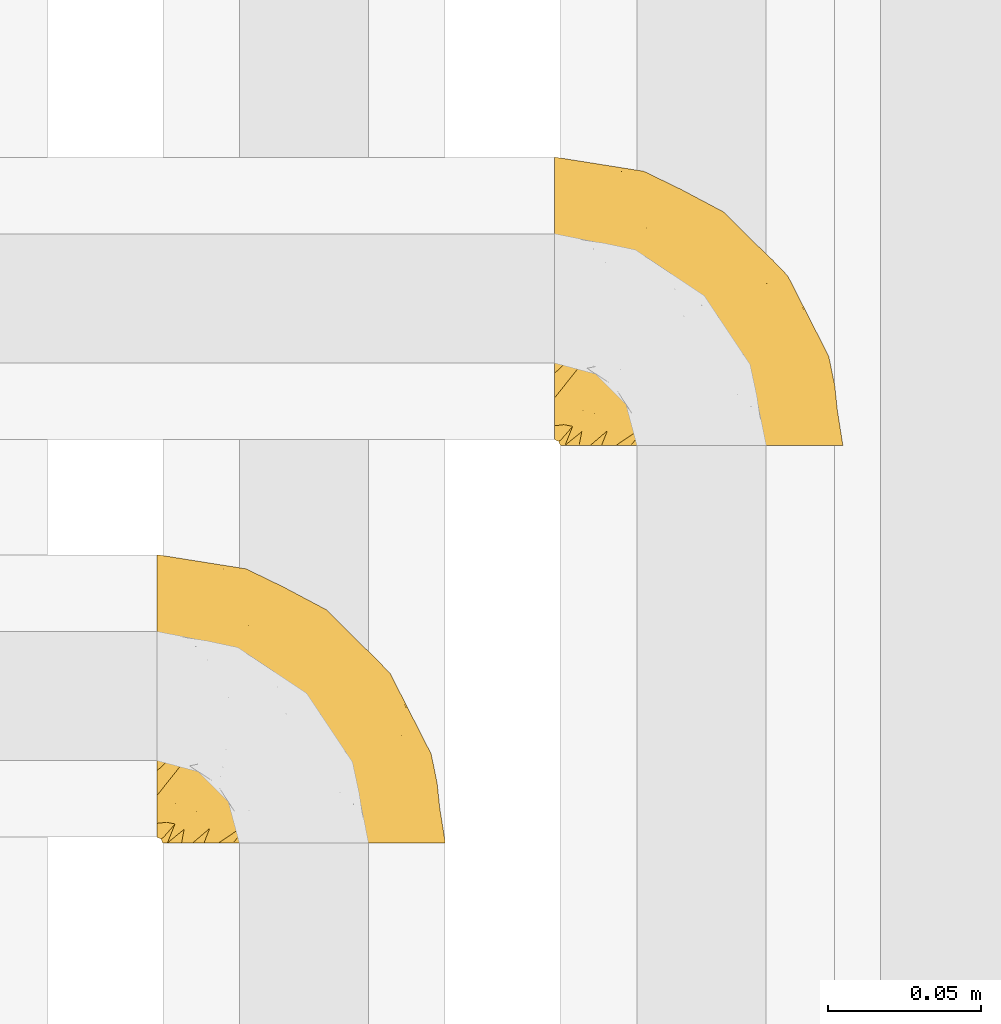
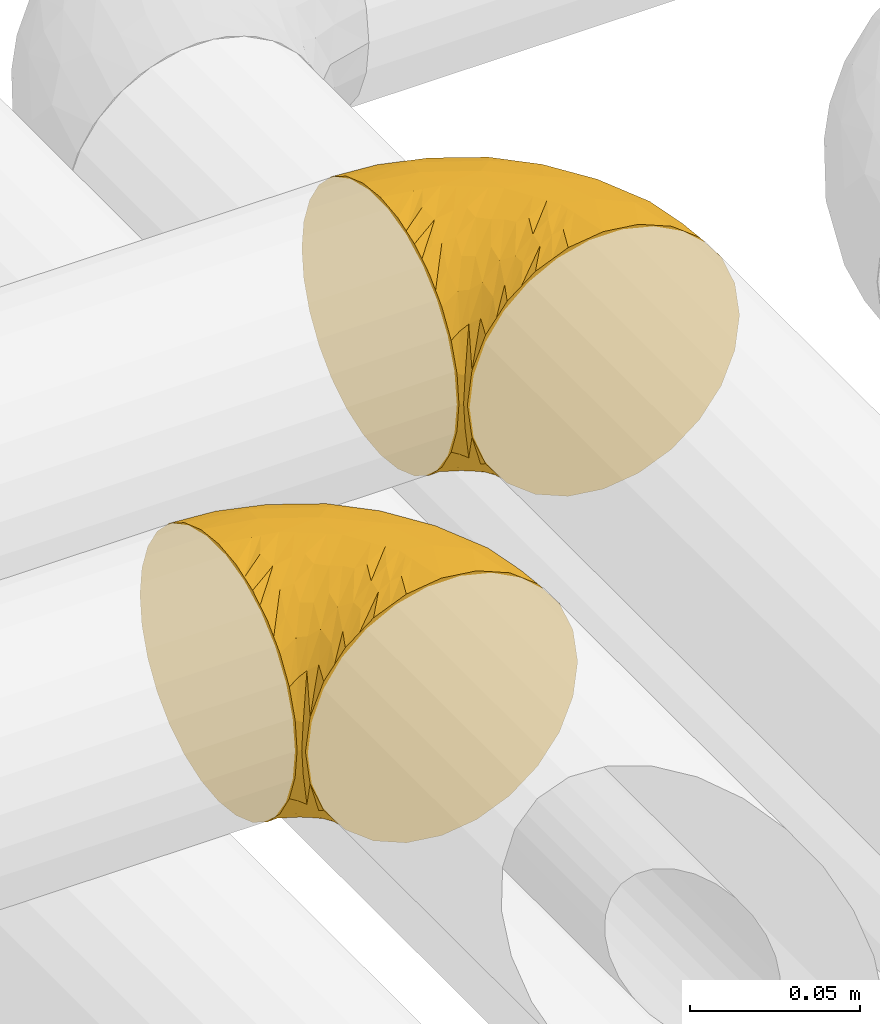
# One storey, part 253 of 827: 2 coverings.
"""IFC2X3 building model written with IfcOpenShell, lengths in millimetres."""

from ifc_helpers import new_model, entity, si_unit, converted_unit, derived_unit, direction, frame, origin, place, context, subcontext, project, spatial, faceted_brep, element, save


model = new_model("IFC2X3")

# Units and contexts
model_context = context("Model", 3, precision=0.01, world=origin(), true_north=direction((6.12303176911189e-17, 1.0)))
body_context = subcontext(model_context, "Body", "Model", "MODEL_VIEW")
ifc_project = project(units=[si_unit("LENGTHUNIT", "METRE", prefix="MILLI"), si_unit("AREAUNIT", "SQUARE_METRE"), si_unit("VOLUMEUNIT", "CUBIC_METRE"), converted_unit("PLANEANGLEUNIT", "DEGREE", entity("IfcRatioMeasure", 0.0174532925199433), si_unit("PLANEANGLEUNIT", "RADIAN"), dimensions=[0, 0, 0, 0, 0, 0, 0]), si_unit("MASSUNIT", "GRAM", prefix="KILO"), derived_unit("MASSDENSITYUNIT", [(si_unit("MASSUNIT", "GRAM", prefix="KILO"), 1), (si_unit("LENGTHUNIT", "METRE"), -3)]), derived_unit("MOMENTOFINERTIAUNIT", [(si_unit("LENGTHUNIT", "METRE"), 4)]), si_unit("TIMEUNIT", "SECOND"), si_unit("FREQUENCYUNIT", "HERTZ"), si_unit("THERMODYNAMICTEMPERATUREUNIT", "DEGREE_CELSIUS"), derived_unit("THERMALTRANSMITTANCEUNIT", [(si_unit("MASSUNIT", "GRAM", prefix="KILO"), 1), (si_unit("THERMODYNAMICTEMPERATUREUNIT", "KELVIN"), -1), (si_unit("TIMEUNIT", "SECOND"), -3)]), derived_unit("VOLUMETRICFLOWRATEUNIT", [(si_unit("LENGTHUNIT", "METRE"), 3), (si_unit("TIMEUNIT", "SECOND"), -1)]), derived_unit("MASSFLOWRATEUNIT", [(si_unit("MASSUNIT", "GRAM", prefix="KILO"), 1), (si_unit("TIMEUNIT", "SECOND"), -1)]), derived_unit("ROTATIONALFREQUENCYUNIT", [(si_unit("TIMEUNIT", "SECOND"), -1)]), si_unit("ELECTRICCURRENTUNIT", "AMPERE"), si_unit("ELECTRICVOLTAGEUNIT", "VOLT"), si_unit("POWERUNIT", "WATT"), si_unit("FORCEUNIT", "NEWTON", prefix="KILO"), si_unit("ILLUMINANCEUNIT", "LUX"), si_unit("LUMINOUSFLUXUNIT", "LUMEN"), si_unit("LUMINOUSINTENSITYUNIT", "CANDELA"), derived_unit("USERDEFINED", [(si_unit("MASSUNIT", "GRAM", prefix="KILO"), -1), (si_unit("LENGTHUNIT", "METRE"), -2), (si_unit("TIMEUNIT", "SECOND"), 3), (si_unit("LUMINOUSFLUXUNIT", "LUMEN"), 1)]), derived_unit("LINEARVELOCITYUNIT", [(si_unit("LENGTHUNIT", "METRE"), 1), (si_unit("TIMEUNIT", "SECOND"), -1)]), si_unit("PRESSUREUNIT", "PASCAL"), derived_unit("USERDEFINED", [(si_unit("LENGTHUNIT", "METRE"), -2), (si_unit("MASSUNIT", "GRAM", prefix="KILO"), 1), (si_unit("TIMEUNIT", "SECOND"), -2)]), derived_unit("LINEARFORCEUNIT", [(si_unit("MASSUNIT", "GRAM", prefix="KILO"), 1), (si_unit("LENGTHUNIT", "METRE"), 1), (si_unit("TIMEUNIT", "SECOND"), -2), (si_unit("LENGTHUNIT", "METRE"), -1)]), derived_unit("PLANARFORCEUNIT", [(si_unit("MASSUNIT", "GRAM", prefix="KILO"), 1), (si_unit("LENGTHUNIT", "METRE"), 1), (si_unit("TIMEUNIT", "SECOND"), -2), (si_unit("LENGTHUNIT", "METRE"), -2)])], contexts=[model_context])

# Site, building, storey
site_placement = place(None, origin())
site = spatial("IfcSite", under=ifc_project, at=site_placement, CompositionType="ELEMENT")
building_placement = place(site_placement, origin())
building = spatial("IfcBuilding", under=site, at=building_placement, CompositionType="ELEMENT")
storey_placement = place(building_placement, frame((0.0, 0.0, 28200.0)))
storey = spatial("IfcBuildingStorey", under=building, at=storey_placement, Name="08", CompositionType="ELEMENT", Elevation=28200.0)

# Coverings
covering_1_placement = place(storey_placement, frame((31126.93, 16011.61, 3152.2)))
element("IfcCovering", 1, at=covering_1_placement, inside=storey, Name=":ADSK_", ObjectType=":ADSK_", PredefinedType="INSULATION", context=body_context, shape_type="Brep", body=[
    faceted_brep([(1.6, 78.41, 83.91), (1.6, 85.72, 76.59), (1.6, 91.22, 67.83), (1.6, 94.64, 58.07), (1.6, 95.8, 47.8), (1.6, 94.64, 37.51), (1.6, 91.22, 27.74), (1.6, 85.71, 18.98), (1.6, 78.39, 11.67), (1.6, 69.63, 6.17), (1.6, 59.87, 2.75), (1.6, 49.6, 1.6), (1.6, 45.45, 2.06), (1.6, 42.38, 2.41), (1.6, 39.31, 2.75), (1.6, 34.43, 4.46), (1.6, 29.54, 6.17), (1.6, 25.16, 8.93), (1.6, 20.78, 11.68), (1.6, 17.13, 15.34), (1.6, 13.47, 19.0), (1.6, 7.97, 27.76), (1.6, 6.26, 32.64), (1.6, 4.55, 37.52), (1.6, 3.4, 47.8), (1.6, 4.55, 58.08), (1.6, 6.26, 62.96), (1.6, 7.97, 67.85), (1.6, 13.48, 76.61), (1.6, 17.14, 80.26), (1.6, 20.8, 83.92), (1.6, 25.18, 86.67), (1.6, 29.56, 89.42), (1.6, 34.44, 91.13), (1.6, 39.32, 92.84), (1.6, 42.39, 93.18), (1.6, 45.45, 93.53), (1.6, 49.6, 94.0), (1.6, 59.88, 92.84), (1.6, 69.65, 89.42), (3.4, 1.6, 47.8), (4.97, 1.6, 35.84), (9.58, 1.6, 24.7), (13.26, 1.6, 19.91), (16.93, 1.6, 15.13), (21.71, 1.6, 11.46), (26.5, 1.6, 7.78), (32.07, 1.6, 5.48), (37.64, 1.6, 3.17), (41.25, 1.6, 2.69), (43.34, 1.6, 2.42), (45.42, 1.6, 2.14), (49.6, 1.6, 1.6), (61.55, 1.6, 3.17), (72.7, 1.6, 7.78), (82.26, 1.6, 15.13), (89.61, 1.6, 24.7), (94.22, 1.6, 35.84), (95.8, 1.6, 47.8), (94.22, 1.6, 59.75), (89.61, 1.6, 70.9), (82.26, 1.6, 80.46), (72.7, 1.6, 87.81), (61.55, 1.6, 92.42), (49.6, 1.6, 94.0), (45.42, 1.6, 93.45), (41.25, 1.6, 92.9), (37.64, 1.6, 92.42), (32.07, 1.6, 90.11), (26.5, 1.6, 87.81), (21.71, 1.6, 84.13), (16.93, 1.6, 80.46), (13.26, 1.6, 75.68), (9.58, 1.6, 70.9), (4.97, 1.6, 59.75), (81.55, 36.81, 71.98), (90.4, 23.28, 63.6), (83.0, 45.8, 59.72), (91.18, 30.7, 47.8), (93.13, 21.2, 55.16), (94.0, 12.96, 47.8), (66.19, 66.19, 63.76), (70.92, 54.51, 72.22), (85.95, 17.98, 74.18), (49.74, 36.69, 92.52), (35.54, 35.54, 94.0), (38.14, 31.64, 94.0), (40.74, 27.75, 94.0), (43.34, 23.86, 94.0), (45.94, 19.96, 94.0), (77.59, 22.8, 82.14), (71.17, 42.67, 80.34), (65.81, 33.21, 87.52), (59.03, 59.45, 79.59), (45.85, 71.5, 78.25), (45.79, 62.66, 85.01), (41.42, 54.5, 90.25), (34.51, 47.57, 93.2), (56.04, 48.81, 87.23), (15.15, 74.98, 85.55), (56.51, 18.7, 93.0), (68.39, 15.75, 89.31), (23.33, 91.17, 61.31), (42.86, 85.28, 56.86), (39.42, 82.58, 68.34), (53.58, 75.78, 65.71), (59.17, 74.98, 56.99), (59.06, 67.27, 72.15), (22.63, 87.38, 70.34), (20.55, 82.04, 78.36), (12.96, 94.0, 47.8), (56.96, 77.8, 47.8), (67.38, 67.38, 47.8), (18.72, 56.2, 93.06), (5.33, 48.85, 94.0), (9.07, 48.11, 94.0), (11.79, 47.57, 94.0), (14.51, 47.03, 94.0), (17.24, 46.48, 94.0), (19.96, 45.94, 94.0), (21.03, 65.78, 89.88), (46.48, 17.24, 94.0), (47.03, 14.51, 94.0), (47.57, 11.79, 94.0), (48.11, 9.07, 94.0), (48.48, 7.2, 94.0), (48.85, 5.33, 94.0), (30.7, 91.18, 47.8), (23.86, 43.34, 94.0), (27.75, 40.74, 94.0), (31.64, 38.14, 94.0), (31.26, 72.73, 83.7), (77.8, 56.96, 47.8), (72.75, 62.23, 55.9), (43.83, 84.49, 47.8), (84.49, 43.83, 47.8), (14.58, 12.05, 81.75), (16.17, 18.95, 86.43), (10.82, 13.02, 79.8), (4.64, 8.34, 69.84), (7.71, 14.63, 79.5), (25.13, 11.09, 88.08), (32.66, 13.66, 91.6), (34.94, 20.08, 92.93), (36.76, 9.61, 92.43), (40.48, 9.48, 93.24), (39.25, 16.1, 93.36), (3.69, 3.42, 57.25), (13.99, 26.63, 89.41), (21.85, 33.72, 92.89), (17.93, 34.77, 92.66), (15.11, 6.75, 79.58), (21.14, 13.31, 86.51), (7.21, 19.94, 83.91), (12.7, 21.11, 86.29), (32.27, 8.67, 90.94), (25.68, 26.11, 91.94), (22.18, 29.3, 91.98), (18.79, 6.32, 82.79), (10.12, 39.92, 93.16), (9.47, 27.05, 88.76), (10.45, 6.04, 73.94), (11.29, 34.4, 91.89), (2.87, 2.87, 47.8), (31.16, 20.92, 92.22), (6.31, 27.43, 88.56), (25.62, 7.54, 87.72), (21.18, 18.45, 88.33), (28.81, 23.88, 92.18), (7.45, 7.77, 71.78), (21.17, 18.43, 7.27), (16.17, 18.93, 9.17), (25.69, 26.08, 3.66), (48.11, 9.07, 1.6), (48.85, 5.33, 1.6), (47.03, 14.51, 1.6), (47.57, 11.79, 1.6), (3.69, 3.42, 38.35), (7.44, 7.76, 23.84), (14.51, 47.03, 1.6), (11.79, 47.57, 1.6), (5.33, 48.85, 1.6), (9.07, 48.11, 1.6), (7.71, 14.62, 16.1), (9.47, 27.03, 6.84), (34.94, 20.08, 2.66), (31.16, 20.92, 3.37), (40.74, 27.75, 1.6), (38.14, 31.64, 1.6), (18.79, 6.33, 12.8), (36.76, 9.61, 3.16), (40.48, 9.48, 2.35), (4.63, 8.33, 25.77), (21.14, 13.3, 9.09), (15.11, 6.74, 16.02), (14.58, 12.04, 13.85), (43.34, 23.86, 1.6), (45.94, 19.96, 1.6), (39.25, 16.1, 2.23), (7.21, 19.93, 11.69), (12.69, 21.1, 9.31), (10.14, 39.92, 2.43), (21.81, 33.68, 2.71), (22.19, 29.28, 3.61), (14.0, 26.62, 6.18), (6.66, 27.87, 6.77), (17.92, 34.75, 2.93), (10.45, 6.04, 21.66), (31.64, 38.14, 1.6), (10.64, 12.79, 16.09), (11.31, 34.41, 3.7), (19.96, 45.94, 1.6), (23.86, 43.34, 1.6), (27.75, 40.74, 1.6), (32.66, 13.66, 3.99), (46.48, 17.24, 1.6), (32.27, 8.67, 4.65), (25.13, 11.09, 7.51), (35.54, 35.54, 1.6), (28.77, 23.83, 3.43), (23.36, 6.03, 9.46), (17.24, 46.48, 1.6), (47.58, 34.52, 2.4), (93.13, 21.2, 40.43), (77.44, 23.82, 13.57), (66.78, 41.32, 11.3), (71.68, 47.62, 18.65), (74.96, 52.66, 27.26), (81.55, 36.81, 23.61), (36.7, 49.75, 3.07), (56.9, 19.07, 2.69), (83.0, 45.8, 35.87), (90.4, 23.28, 31.99), (67.83, 21.35, 6.71), (85.95, 17.98, 21.41), (39.41, 82.57, 27.24), (23.33, 91.17, 34.26), (42.87, 85.27, 38.73), (53.92, 73.89, 26.97), (66.19, 66.19, 31.83), (64.12, 62.43, 23.4), (33.13, 63.53, 6.91), (23.1, 58.45, 3.4), (16.98, 67.16, 5.84), (55.72, 76.72, 35.73), (72.75, 62.22, 39.69), (23.77, 81.54, 17.6), (18.41, 74.8, 10.38), (43.7, 75.83, 20.6), (54.53, 41.45, 5.36), (17.73, 88.2, 24.84), (38.98, 71.6, 13.87), (50.28, 56.23, 9.06), (59.02, 59.44, 15.99)], [[[0, 1, 2, 3, 4, 5, 6, 7, 8, 9, 10, 11, 12, 13, 14, 15, 16, 17, 18, 19, 20, 21, 22, 23, 24, 25, 26, 27, 28, 29, 30, 31, 32, 33, 34, 35, 36, 37, 38, 39]], [[40, 41, 42, 43, 44, 45, 46, 47, 48, 49, 50, 51, 52, 53, 54, 55, 56, 57, 58, 59, 60, 61, 62, 63, 64, 65, 66, 67, 68, 69, 70, 71, 72, 73, 74]], [[75, 76, 77]], [[78, 79, 80]], [[77, 81, 82]], [[76, 75, 83]], [[84, 85, 86, 87, 88, 89]], [[90, 91, 92]], [[76, 60, 59]], [[93, 94, 95]], [[90, 62, 61]], [[83, 61, 60]], [[96, 97, 84]], [[98, 93, 95]], [[0, 39, 99]], [[100, 84, 89]], [[62, 101, 63]], [[2, 102, 3]], [[92, 84, 100]], [[103, 102, 104]], [[103, 105, 106]], [[93, 107, 94]], [[1, 108, 2]], [[92, 101, 90]], [[108, 1, 109]], [[102, 110, 3]], [[93, 82, 107]], [[102, 108, 104]], [[111, 106, 112]], [[109, 0, 99]], [[113, 37, 114, 115, 116, 117, 118, 119]], [[120, 38, 113]], [[100, 89, 121, 122, 123, 124, 125, 126, 64]], [[127, 102, 103]], [[97, 119, 128, 129, 130, 85]], [[99, 120, 131]], [[132, 133, 77]], [[59, 80, 79]], [[1, 0, 109]], [[98, 84, 92]], [[94, 109, 131]], [[120, 39, 38]], [[93, 91, 82]], [[104, 94, 105]], [[97, 113, 119]], [[95, 120, 96]], [[83, 90, 61]], [[91, 93, 98]], [[64, 63, 100]], [[100, 63, 101]], [[77, 76, 79]], [[133, 106, 81]], [[84, 97, 85]], [[113, 96, 120]], [[113, 97, 96]], [[37, 113, 38]], [[110, 102, 127]], [[110, 4, 3]], [[103, 111, 134, 127]], [[90, 75, 91]], [[82, 81, 107]], [[91, 75, 82]], [[77, 82, 75]], [[76, 83, 60]], [[90, 83, 75]], [[105, 107, 81]], [[94, 131, 95]], [[105, 94, 107]], [[109, 94, 104]], [[120, 95, 131]], [[98, 95, 96]], [[84, 98, 96]], [[98, 92, 91]], [[106, 105, 81]], [[103, 104, 105]], [[133, 132, 112]], [[103, 106, 111]], [[77, 78, 135, 132]], [[106, 133, 112]], [[77, 133, 81]], [[120, 99, 39]], [[109, 99, 131]], [[59, 58, 80]], [[59, 79, 76]], [[90, 101, 62]], [[100, 101, 92]], [[2, 108, 102]], [[109, 104, 108]], [[78, 77, 79]], [[136, 137, 138]], [[27, 139, 140]], [[141, 142, 143]], [[144, 145, 121]], [[146, 89, 88]], [[147, 139, 25]], [[148, 149, 150]], [[136, 151, 152]], [[147, 40, 74]], [[24, 147, 25]], [[153, 140, 154]], [[33, 116, 34]], [[73, 72, 151]], [[114, 37, 36, 35, 34, 116, 115]], [[146, 155, 144]], [[156, 85, 130]], [[157, 149, 148]], [[151, 158, 152]], [[117, 33, 159]], [[29, 153, 160]], [[161, 74, 73]], [[162, 128, 119]], [[66, 65, 64, 126, 125, 124, 123, 122, 67]], [[163, 147, 24]], [[27, 140, 28]], [[149, 129, 150]], [[139, 27, 26, 25]], [[68, 144, 69]], [[129, 128, 150]], [[164, 87, 86]], [[130, 129, 149]], [[122, 145, 67]], [[153, 154, 148]], [[162, 119, 159]], [[165, 30, 160]], [[150, 160, 148]], [[128, 162, 150]], [[30, 165, 31]], [[145, 144, 68]], [[89, 146, 144]], [[87, 164, 143]], [[166, 155, 142]], [[88, 87, 143]], [[162, 160, 150]], [[160, 30, 29]], [[160, 153, 148]], [[28, 140, 153]], [[29, 28, 153]], [[140, 137, 154]], [[157, 148, 154]], [[156, 130, 157]], [[154, 137, 157]], [[157, 137, 156]], [[167, 137, 136]], [[168, 85, 156]], [[152, 168, 167]], [[167, 168, 156]], [[164, 152, 141]], [[71, 158, 72]], [[152, 167, 136]], [[88, 142, 146]], [[144, 155, 69]], [[146, 142, 155]], [[70, 166, 71]], [[142, 141, 166]], [[70, 69, 155]], [[141, 158, 71]], [[161, 73, 151]], [[138, 137, 140]], [[161, 136, 169]], [[136, 161, 151]], [[74, 161, 169]], [[152, 158, 141]], [[151, 72, 158]], [[168, 152, 164]], [[137, 167, 156]], [[164, 86, 168]], [[85, 168, 86]], [[116, 33, 117]], [[130, 149, 157]], [[67, 145, 68]], [[121, 89, 144]], [[145, 122, 121]], [[40, 147, 163]], [[169, 147, 74]], [[159, 33, 32]], [[162, 159, 32]], [[159, 119, 118, 117]], [[139, 147, 169]], [[139, 169, 138]], [[162, 32, 31]], [[141, 143, 164]], [[88, 143, 142]], [[71, 166, 141]], [[155, 166, 70]], [[139, 138, 140]], [[169, 136, 138]], [[160, 162, 165]], [[162, 31, 165]], [[170, 171, 172]], [[173, 174, 52, 51, 50, 49, 48, 175, 176]], [[177, 178, 41]], [[179, 15, 180]], [[12, 11, 181, 182, 180, 14, 13]], [[183, 21, 20]], [[19, 18, 184]], [[185, 186, 187]], [[186, 188, 187]], [[43, 189, 44]], [[190, 191, 47]], [[23, 22, 21, 192]], [[193, 194, 195]], [[40, 163, 177]], [[196, 197, 198]], [[24, 23, 177]], [[199, 200, 183]], [[201, 15, 179]], [[47, 46, 190]], [[202, 203, 204]], [[203, 172, 171]], [[205, 206, 184]], [[207, 41, 178]], [[16, 15, 201]], [[14, 180, 15]], [[204, 203, 200]], [[208, 203, 202]], [[163, 24, 177]], [[48, 47, 191]], [[198, 197, 190]], [[199, 184, 204]], [[171, 195, 209]], [[210, 211, 212]], [[206, 212, 213]], [[205, 17, 210]], [[184, 206, 204]], [[210, 212, 206]], [[185, 196, 214]], [[190, 215, 191]], [[216, 45, 214]], [[186, 217, 193]], [[190, 216, 198]], [[199, 20, 19]], [[196, 185, 187]], [[199, 183, 20]], [[184, 199, 19]], [[199, 204, 200]], [[206, 202, 204]], [[171, 183, 200]], [[203, 208, 172]], [[172, 208, 218]], [[171, 200, 203]], [[218, 188, 219]], [[195, 170, 193]], [[217, 186, 185]], [[193, 219, 186]], [[193, 170, 219]], [[207, 194, 42]], [[217, 220, 189]], [[216, 190, 46]], [[214, 196, 198]], [[44, 220, 45]], [[214, 198, 216]], [[216, 46, 45]], [[214, 45, 220]], [[42, 194, 43]], [[189, 193, 217]], [[207, 195, 194]], [[209, 195, 178]], [[41, 207, 42]], [[195, 207, 178]], [[43, 194, 189]], [[193, 189, 194]], [[171, 170, 195]], [[170, 172, 219]], [[218, 219, 172]], [[188, 186, 219]], [[206, 213, 202]], [[208, 202, 213]], [[201, 210, 16]], [[215, 190, 197]], [[215, 175, 191]], [[175, 48, 191]], [[201, 179, 221, 211]], [[210, 201, 211]], [[23, 192, 177]], [[40, 177, 41]], [[178, 177, 192]], [[21, 183, 192]], [[209, 192, 183]], [[205, 18, 17]], [[17, 16, 210]], [[217, 185, 214]], [[189, 220, 44]], [[214, 220, 217]], [[192, 209, 178]], [[171, 209, 183]], [[206, 205, 210]], [[18, 205, 184]], [[222, 197, 196, 187, 188, 218]], [[57, 223, 80]], [[224, 225, 226]], [[226, 227, 228]], [[229, 218, 208, 213, 212, 211]], [[230, 52, 174, 173, 176, 175, 215, 197]], [[231, 232, 228]], [[231, 78, 223]], [[223, 57, 232]], [[224, 233, 225]], [[233, 54, 53]], [[234, 232, 56]], [[56, 55, 234]], [[234, 224, 228]], [[235, 236, 237]], [[224, 55, 54]], [[238, 239, 240]], [[52, 230, 53]], [[241, 242, 243]], [[239, 244, 245]], [[11, 10, 242]], [[236, 6, 5]], [[7, 246, 8]], [[8, 247, 9]], [[238, 248, 235]], [[222, 229, 249]], [[242, 211, 221, 179, 180, 182, 181, 11]], [[233, 53, 230]], [[111, 112, 244]], [[250, 6, 236]], [[247, 251, 241]], [[6, 250, 7]], [[127, 236, 110]], [[249, 229, 252]], [[247, 8, 246]], [[235, 246, 250]], [[236, 5, 110]], [[235, 244, 238]], [[237, 236, 127]], [[243, 9, 247]], [[252, 229, 241]], [[56, 232, 57]], [[222, 230, 197]], [[225, 249, 252]], [[249, 233, 230]], [[54, 233, 224]], [[231, 228, 227]], [[245, 132, 231]], [[249, 225, 233]], [[226, 225, 253]], [[235, 250, 236]], [[246, 7, 250]], [[251, 247, 246]], [[243, 247, 241]], [[248, 246, 235]], [[252, 251, 253]], [[229, 222, 218]], [[230, 222, 249]], [[5, 4, 110]], [[237, 127, 134, 111]], [[238, 244, 239]], [[224, 234, 55]], [[232, 234, 228]], [[242, 241, 229]], [[10, 9, 243]], [[211, 242, 229]], [[10, 243, 242]], [[80, 223, 78]], [[80, 58, 57]], [[231, 223, 232]], [[227, 240, 239]], [[224, 226, 228]], [[240, 226, 253]], [[227, 239, 245]], [[226, 240, 227]], [[251, 248, 253]], [[240, 253, 248]], [[244, 235, 237]], [[237, 111, 244]], [[132, 245, 112]], [[112, 245, 244]], [[135, 78, 231, 132]], [[227, 245, 231]], [[248, 238, 240]], [[246, 248, 251]], [[251, 252, 241]], [[225, 252, 253]]]),
])
covering_2_placement = place(storey_placement, frame((31256.93, 16141.61, 3152.2)))
element("IfcCovering", 2, at=covering_2_placement, inside=storey, Name=":ADSK_", ObjectType=":ADSK_", PredefinedType="INSULATION", context=body_context, shape_type="Brep", body=[
    faceted_brep([(1.6, 78.41, 83.91), (1.6, 85.72, 76.59), (1.6, 91.22, 67.83), (1.6, 94.64, 58.07), (1.6, 95.8, 47.8), (1.6, 94.64, 37.51), (1.6, 91.22, 27.74), (1.6, 85.71, 18.98), (1.6, 78.39, 11.67), (1.6, 69.63, 6.17), (1.6, 59.87, 2.75), (1.6, 49.6, 1.6), (1.6, 45.45, 2.06), (1.6, 42.38, 2.41), (1.6, 39.31, 2.75), (1.6, 34.43, 4.46), (1.6, 29.54, 6.17), (1.6, 25.16, 8.93), (1.6, 20.78, 11.68), (1.6, 17.13, 15.34), (1.6, 13.47, 19.0), (1.6, 7.97, 27.76), (1.6, 6.26, 32.64), (1.6, 4.55, 37.52), (1.6, 3.4, 47.8), (1.6, 4.55, 58.08), (1.6, 6.26, 62.96), (1.6, 7.97, 67.85), (1.6, 13.48, 76.61), (1.6, 17.14, 80.26), (1.6, 20.8, 83.92), (1.6, 25.18, 86.67), (1.6, 29.56, 89.42), (1.6, 34.44, 91.13), (1.6, 39.32, 92.84), (1.6, 42.39, 93.18), (1.6, 45.45, 93.53), (1.6, 49.6, 94.0), (1.6, 59.88, 92.84), (1.6, 69.65, 89.42), (3.4, 1.6, 47.8), (4.97, 1.6, 35.84), (9.58, 1.6, 24.7), (13.26, 1.6, 19.91), (16.93, 1.6, 15.13), (21.71, 1.6, 11.46), (26.5, 1.6, 7.78), (32.07, 1.6, 5.48), (37.64, 1.6, 3.17), (41.25, 1.6, 2.69), (43.34, 1.6, 2.42), (45.42, 1.6, 2.14), (49.6, 1.6, 1.6), (61.55, 1.6, 3.17), (72.7, 1.6, 7.78), (82.26, 1.6, 15.13), (89.61, 1.6, 24.7), (94.22, 1.6, 35.84), (95.8, 1.6, 47.8), (94.22, 1.6, 59.75), (89.61, 1.6, 70.9), (82.26, 1.6, 80.46), (72.7, 1.6, 87.81), (61.55, 1.6, 92.42), (49.6, 1.6, 94.0), (45.42, 1.6, 93.45), (41.25, 1.6, 92.9), (37.64, 1.6, 92.42), (32.07, 1.6, 90.11), (26.5, 1.6, 87.81), (21.71, 1.6, 84.13), (16.93, 1.6, 80.46), (13.26, 1.6, 75.68), (9.58, 1.6, 70.9), (4.97, 1.6, 59.75), (81.55, 36.81, 71.98), (90.4, 23.28, 63.6), (83.0, 45.8, 59.72), (91.18, 30.7, 47.8), (93.13, 21.2, 55.16), (94.0, 12.96, 47.8), (66.19, 66.19, 63.76), (70.92, 54.51, 72.22), (85.95, 17.98, 74.18), (49.74, 36.69, 92.52), (35.54, 35.54, 94.0), (38.14, 31.64, 94.0), (40.74, 27.75, 94.0), (43.34, 23.86, 94.0), (45.94, 19.96, 94.0), (77.59, 22.8, 82.14), (71.17, 42.67, 80.34), (65.81, 33.21, 87.52), (59.03, 59.45, 79.59), (45.85, 71.5, 78.25), (45.79, 62.66, 85.01), (41.42, 54.5, 90.25), (34.51, 47.57, 93.2), (56.04, 48.81, 87.23), (15.15, 74.98, 85.55), (56.51, 18.7, 93.0), (68.39, 15.75, 89.31), (23.33, 91.17, 61.31), (42.86, 85.28, 56.86), (39.42, 82.58, 68.34), (53.58, 75.78, 65.71), (59.17, 74.98, 56.99), (59.06, 67.27, 72.15), (22.63, 87.38, 70.34), (20.55, 82.04, 78.36), (12.96, 94.0, 47.8), (56.96, 77.8, 47.8), (67.38, 67.38, 47.8), (18.72, 56.2, 93.06), (5.33, 48.85, 94.0), (9.07, 48.11, 94.0), (11.79, 47.57, 94.0), (14.51, 47.03, 94.0), (17.24, 46.48, 94.0), (19.96, 45.94, 94.0), (21.03, 65.78, 89.88), (46.48, 17.24, 94.0), (47.03, 14.51, 94.0), (47.57, 11.79, 94.0), (48.11, 9.07, 94.0), (48.48, 7.2, 94.0), (48.85, 5.33, 94.0), (30.7, 91.18, 47.8), (23.86, 43.34, 94.0), (27.75, 40.74, 94.0), (31.64, 38.14, 94.0), (31.26, 72.73, 83.7), (77.8, 56.96, 47.8), (72.75, 62.23, 55.9), (43.83, 84.49, 47.8), (84.49, 43.83, 47.8), (14.58, 12.05, 81.75), (16.17, 18.95, 86.43), (10.82, 13.02, 79.8), (4.64, 8.34, 69.84), (7.71, 14.63, 79.5), (25.13, 11.09, 88.08), (32.66, 13.66, 91.6), (34.94, 20.08, 92.93), (36.76, 9.61, 92.43), (40.48, 9.48, 93.24), (39.25, 16.1, 93.36), (3.69, 3.42, 57.25), (13.99, 26.63, 89.41), (21.85, 33.72, 92.89), (17.93, 34.77, 92.66), (15.11, 6.75, 79.58), (21.14, 13.31, 86.51), (7.21, 19.94, 83.91), (9.47, 27.05, 88.76), (10.45, 6.04, 73.94), (32.27, 8.67, 90.94), (25.68, 26.11, 91.94), (22.18, 29.3, 91.98), (18.79, 6.32, 82.79), (10.12, 39.92, 93.16), (11.29, 34.4, 91.89), (2.87, 2.87, 47.8), (31.16, 20.92, 92.22), (12.7, 21.11, 86.29), (6.31, 27.43, 88.56), (25.62, 7.54, 87.72), (21.18, 18.45, 88.33), (28.81, 23.88, 92.18), (7.45, 7.77, 71.78), (21.14, 13.3, 9.09), (25.13, 11.09, 7.51), (18.79, 6.33, 12.8), (48.11, 9.07, 1.6), (48.85, 5.33, 1.6), (47.03, 14.51, 1.6), (47.57, 11.79, 1.6), (3.69, 3.42, 38.35), (7.44, 7.76, 23.84), (14.51, 47.03, 1.6), (11.79, 47.57, 1.6), (5.33, 48.85, 1.6), (9.07, 48.11, 1.6), (7.71, 14.62, 16.1), (9.47, 27.03, 6.84), (34.94, 20.08, 2.66), (31.16, 20.92, 3.37), (40.74, 27.75, 1.6), (38.14, 31.64, 1.6), (36.76, 9.61, 3.16), (40.48, 9.48, 2.35), (4.63, 8.33, 25.77), (15.11, 6.74, 16.02), (14.58, 12.04, 13.85), (43.34, 23.86, 1.6), (45.94, 19.96, 1.6), (39.25, 16.1, 2.23), (7.21, 19.93, 11.69), (12.69, 21.1, 9.31), (10.14, 39.92, 2.43), (21.81, 33.68, 2.71), (22.19, 29.28, 3.61), (14.0, 26.62, 6.18), (25.69, 26.08, 3.66), (16.17, 18.93, 9.17), (6.66, 27.87, 6.77), (17.92, 34.75, 2.93), (10.45, 6.04, 21.66), (31.64, 38.14, 1.6), (10.64, 12.79, 16.09), (11.31, 34.41, 3.7), (19.96, 45.94, 1.6), (23.86, 43.34, 1.6), (27.75, 40.74, 1.6), (32.66, 13.66, 3.99), (46.48, 17.24, 1.6), (32.27, 8.67, 4.65), (35.54, 35.54, 1.6), (28.77, 23.83, 3.43), (21.17, 18.43, 7.27), (23.36, 6.03, 9.46), (17.24, 46.48, 1.6), (47.58, 34.52, 2.4), (93.13, 21.2, 40.43), (77.44, 23.82, 13.57), (66.78, 41.32, 11.3), (71.68, 47.62, 18.65), (74.96, 52.66, 27.26), (81.55, 36.81, 23.61), (36.7, 49.75, 3.07), (56.9, 19.07, 2.69), (83.0, 45.8, 35.87), (90.4, 23.28, 31.99), (67.83, 21.35, 6.71), (85.95, 17.98, 21.41), (39.41, 82.57, 27.24), (23.33, 91.17, 34.26), (42.87, 85.27, 38.73), (53.92, 73.89, 26.97), (66.19, 66.19, 31.83), (64.12, 62.43, 23.4), (33.13, 63.53, 6.91), (23.1, 58.45, 3.4), (16.98, 67.16, 5.84), (72.75, 62.22, 39.69), (23.77, 81.54, 17.6), (18.41, 74.8, 10.38), (43.7, 75.83, 20.6), (54.53, 41.45, 5.36), (55.72, 76.72, 35.73), (17.73, 88.2, 24.84), (38.98, 71.6, 13.87), (50.28, 56.23, 9.06), (59.02, 59.44, 15.99)], [[[0, 1, 2, 3, 4, 5, 6, 7, 8, 9, 10, 11, 12, 13, 14, 15, 16, 17, 18, 19, 20, 21, 22, 23, 24, 25, 26, 27, 28, 29, 30, 31, 32, 33, 34, 35, 36, 37, 38, 39]], [[40, 41, 42, 43, 44, 45, 46, 47, 48, 49, 50, 51, 52, 53, 54, 55, 56, 57, 58, 59, 60, 61, 62, 63, 64, 65, 66, 67, 68, 69, 70, 71, 72, 73, 74]], [[75, 76, 77]], [[78, 79, 80]], [[77, 81, 82]], [[76, 75, 83]], [[84, 85, 86, 87, 88, 89]], [[90, 91, 92]], [[76, 60, 59]], [[93, 94, 95]], [[90, 62, 61]], [[83, 61, 60]], [[96, 97, 84]], [[98, 93, 95]], [[0, 39, 99]], [[100, 84, 89]], [[62, 101, 63]], [[2, 102, 3]], [[92, 84, 100]], [[103, 102, 104]], [[103, 105, 106]], [[93, 107, 94]], [[1, 108, 2]], [[92, 101, 90]], [[108, 1, 109]], [[102, 110, 3]], [[93, 82, 107]], [[102, 108, 104]], [[111, 106, 112]], [[109, 0, 99]], [[113, 37, 114, 115, 116, 117, 118, 119]], [[120, 38, 113]], [[100, 89, 121, 122, 123, 124, 125, 126, 64]], [[127, 102, 103]], [[97, 119, 128, 129, 130, 85]], [[99, 120, 131]], [[132, 133, 77]], [[59, 80, 79]], [[1, 0, 109]], [[98, 84, 92]], [[94, 109, 131]], [[120, 39, 38]], [[93, 91, 82]], [[104, 94, 105]], [[97, 113, 119]], [[95, 120, 96]], [[83, 90, 61]], [[91, 93, 98]], [[64, 63, 100]], [[100, 63, 101]], [[77, 76, 79]], [[133, 106, 81]], [[84, 97, 85]], [[113, 96, 120]], [[113, 97, 96]], [[37, 113, 38]], [[110, 102, 127]], [[110, 4, 3]], [[103, 111, 134, 127]], [[90, 75, 91]], [[82, 81, 107]], [[91, 75, 82]], [[77, 82, 75]], [[76, 83, 60]], [[90, 83, 75]], [[105, 107, 81]], [[94, 131, 95]], [[105, 94, 107]], [[109, 94, 104]], [[120, 95, 131]], [[98, 95, 96]], [[84, 98, 96]], [[98, 92, 91]], [[106, 105, 81]], [[103, 104, 105]], [[133, 132, 112]], [[103, 106, 111]], [[77, 78, 135, 132]], [[106, 133, 112]], [[77, 133, 81]], [[120, 99, 39]], [[109, 99, 131]], [[59, 58, 80]], [[59, 79, 76]], [[90, 101, 62]], [[100, 101, 92]], [[2, 108, 102]], [[109, 104, 108]], [[78, 77, 79]], [[136, 137, 138]], [[27, 139, 140]], [[141, 142, 143]], [[144, 145, 121]], [[146, 89, 88]], [[147, 139, 25]], [[148, 149, 150]], [[136, 151, 152]], [[147, 40, 74]], [[24, 147, 25]], [[153, 148, 154]], [[33, 116, 34]], [[73, 151, 155]], [[114, 37, 36, 35, 34, 116, 115]], [[146, 156, 144]], [[157, 85, 130]], [[158, 149, 148]], [[151, 159, 152]], [[117, 33, 160]], [[29, 153, 154]], [[155, 74, 73]], [[161, 128, 119]], [[65, 64, 126, 125, 124, 123, 122, 67, 66]], [[162, 147, 24]], [[27, 140, 28]], [[149, 129, 150]], [[139, 27, 26, 25]], [[68, 144, 69]], [[129, 128, 150]], [[163, 87, 86]], [[130, 129, 149]], [[122, 145, 67]], [[153, 164, 148]], [[161, 119, 160]], [[165, 30, 154]], [[150, 154, 148]], [[128, 161, 150]], [[30, 165, 31]], [[145, 144, 68]], [[89, 146, 144]], [[87, 163, 143]], [[166, 156, 142]], [[88, 87, 143]], [[161, 154, 150]], [[154, 30, 29]], [[29, 28, 153]], [[28, 140, 153]], [[164, 153, 140]], [[140, 137, 164]], [[158, 148, 164]], [[157, 130, 158]], [[164, 137, 158]], [[158, 137, 157]], [[167, 137, 136]], [[168, 85, 157]], [[152, 168, 167]], [[167, 168, 157]], [[163, 152, 141]], [[151, 73, 72]], [[159, 72, 71]], [[88, 142, 146]], [[144, 156, 69]], [[146, 142, 156]], [[70, 166, 71]], [[142, 141, 166]], [[70, 69, 156]], [[141, 159, 71]], [[167, 136, 152]], [[138, 137, 140]], [[155, 136, 169]], [[136, 155, 151]], [[74, 155, 169]], [[152, 159, 141]], [[151, 72, 159]], [[168, 152, 163]], [[137, 167, 157]], [[163, 86, 168]], [[85, 168, 86]], [[116, 33, 117]], [[130, 149, 158]], [[67, 145, 68]], [[121, 89, 144]], [[145, 122, 121]], [[40, 147, 162]], [[169, 147, 74]], [[160, 33, 32]], [[161, 160, 32]], [[160, 119, 118, 117]], [[139, 147, 169]], [[139, 169, 138]], [[161, 32, 31]], [[141, 143, 163]], [[88, 143, 142]], [[71, 166, 141]], [[156, 166, 70]], [[139, 138, 140]], [[169, 136, 138]], [[154, 161, 165]], [[161, 31, 165]], [[170, 171, 172]], [[173, 174, 52, 51, 50, 49, 48, 175, 176]], [[177, 178, 41]], [[179, 15, 180]], [[12, 11, 181, 182, 180, 14, 13]], [[183, 21, 20]], [[19, 18, 184]], [[185, 186, 187]], [[186, 188, 187]], [[43, 172, 44]], [[189, 190, 47]], [[23, 22, 21, 191]], [[170, 192, 193]], [[40, 162, 177]], [[194, 195, 196]], [[24, 23, 177]], [[197, 198, 183]], [[199, 15, 179]], [[47, 46, 189]], [[200, 201, 202]], [[201, 203, 204]], [[205, 206, 184]], [[207, 41, 178]], [[16, 15, 199]], [[14, 180, 15]], [[202, 201, 198]], [[208, 201, 200]], [[162, 24, 177]], [[48, 47, 190]], [[196, 195, 189]], [[197, 184, 202]], [[204, 193, 209]], [[210, 211, 212]], [[206, 212, 213]], [[205, 17, 210]], [[184, 206, 202]], [[210, 212, 206]], [[185, 194, 214]], [[189, 215, 190]], [[216, 45, 214]], [[186, 171, 170]], [[189, 216, 196]], [[197, 20, 19]], [[194, 185, 187]], [[197, 183, 20]], [[184, 197, 19]], [[197, 202, 198]], [[206, 200, 202]], [[204, 183, 198]], [[201, 208, 203]], [[203, 208, 217]], [[204, 198, 201]], [[217, 188, 218]], [[193, 219, 170]], [[171, 186, 185]], [[170, 218, 186]], [[170, 219, 218]], [[42, 207, 192]], [[171, 220, 172]], [[216, 189, 46]], [[214, 194, 196]], [[44, 220, 45]], [[214, 196, 216]], [[216, 46, 45]], [[214, 45, 220]], [[192, 43, 42]], [[204, 203, 219]], [[207, 193, 192]], [[209, 193, 178]], [[41, 207, 42]], [[193, 207, 178]], [[43, 192, 172]], [[170, 172, 192]], [[204, 219, 193]], [[219, 203, 218]], [[217, 218, 203]], [[188, 186, 218]], [[206, 213, 200]], [[208, 200, 213]], [[199, 210, 16]], [[215, 189, 195]], [[215, 175, 190]], [[175, 48, 190]], [[199, 179, 221, 211]], [[210, 199, 211]], [[23, 191, 177]], [[40, 177, 41]], [[183, 209, 191]], [[183, 191, 21]], [[191, 178, 177]], [[205, 18, 17]], [[17, 16, 210]], [[171, 185, 214]], [[172, 220, 44]], [[214, 220, 171]], [[191, 209, 178]], [[204, 209, 183]], [[206, 205, 210]], [[18, 205, 184]], [[222, 195, 194, 187, 188, 217]], [[57, 223, 80]], [[224, 225, 226]], [[226, 227, 228]], [[229, 217, 208, 213, 212, 211]], [[230, 52, 174, 173, 176, 175, 215, 195]], [[231, 232, 228]], [[231, 78, 223]], [[223, 57, 232]], [[224, 233, 225]], [[233, 54, 53]], [[234, 232, 56]], [[56, 55, 234]], [[234, 224, 228]], [[235, 236, 237]], [[224, 55, 54]], [[238, 239, 240]], [[52, 230, 53]], [[241, 242, 243]], [[227, 244, 231]], [[11, 10, 242]], [[236, 6, 5]], [[7, 245, 8]], [[8, 246, 9]], [[238, 247, 235]], [[222, 229, 248]], [[242, 211, 221, 179, 180, 182, 181, 11]], [[233, 53, 230]], [[111, 112, 249]], [[250, 6, 236]], [[246, 251, 241]], [[6, 250, 7]], [[127, 236, 110]], [[248, 229, 252]], [[246, 8, 245]], [[235, 245, 250]], [[236, 5, 110]], [[235, 249, 238]], [[237, 236, 127]], [[243, 9, 246]], [[252, 229, 241]], [[56, 232, 57]], [[222, 230, 195]], [[225, 248, 252]], [[248, 233, 230]], [[54, 233, 224]], [[231, 228, 227]], [[244, 132, 231]], [[248, 225, 233]], [[226, 225, 253]], [[235, 250, 236]], [[245, 7, 250]], [[251, 246, 245]], [[243, 246, 241]], [[247, 245, 235]], [[252, 251, 253]], [[229, 222, 217]], [[230, 222, 248]], [[5, 4, 110]], [[237, 127, 134, 111]], [[238, 249, 239]], [[224, 234, 55]], [[232, 234, 228]], [[242, 241, 229]], [[10, 9, 243]], [[211, 242, 229]], [[10, 243, 242]], [[80, 223, 78]], [[80, 58, 57]], [[231, 223, 232]], [[227, 240, 239]], [[224, 226, 228]], [[240, 226, 253]], [[227, 239, 244]], [[226, 240, 227]], [[251, 247, 253]], [[240, 253, 247]], [[249, 235, 237]], [[237, 111, 249]], [[112, 132, 244]], [[112, 244, 249]], [[78, 231, 132, 135]], [[249, 244, 239]], [[247, 238, 240]], [[245, 247, 251]], [[251, 252, 241]], [[225, 252, 253]]]),
])

save(model, "model.ifc")
